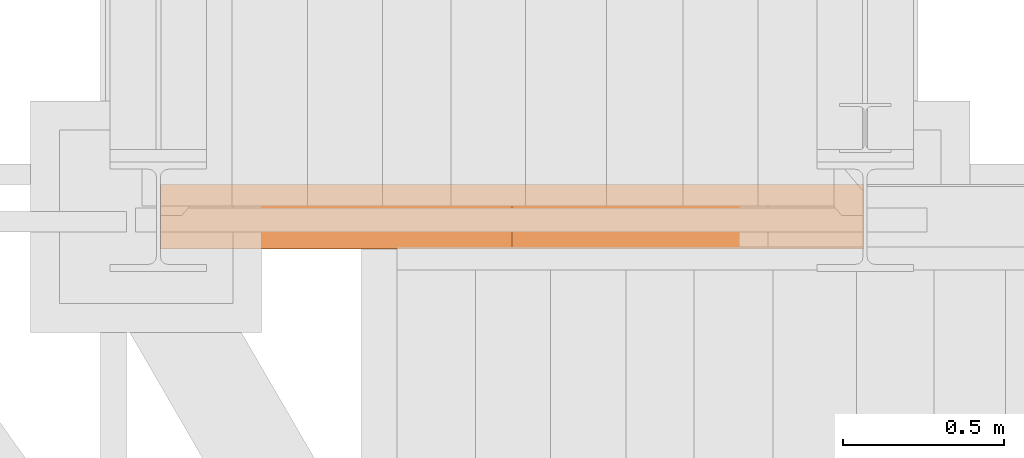
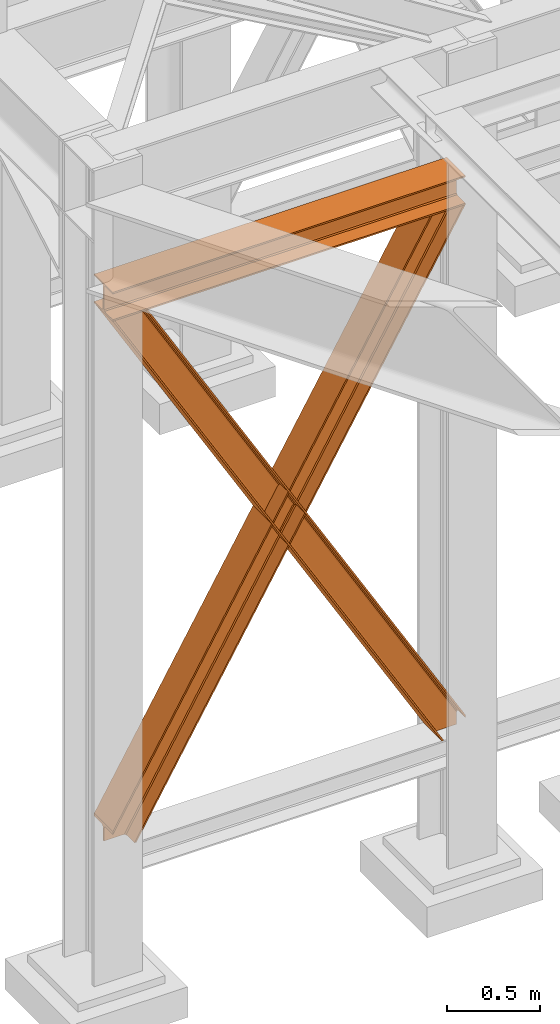
# One storey, part 20 of 208: 3 proxies.
"""IFC2X3 building model written with IfcOpenShell, lengths in millimetres."""

from ifc_helpers import new_model, entity, si_unit, converted_unit, frame, origin, origin_with_axes, place, context, subcontext, project, spatial, faceted_brep, element, save


model = new_model("IFC2X3")

# Units and contexts
model_context = context("Model", 3, precision=1e-05, world=origin())
plan_context = context("Plan", 3, precision=1e-05, world=origin())
body_context = subcontext(model_context, "Body", "Model", "MODEL_VIEW")
ifc_project = project(units=[si_unit("LENGTHUNIT", "METRE", prefix="MILLI"), converted_unit("PLANEANGLEUNIT", "DEGREE", entity("IfcPlaneAngleMeasure", 0.0174532925199433), si_unit("PLANEANGLEUNIT", "RADIAN"), dimensions=[0, 0, 0, 0, 0, 0, 0]), si_unit("AREAUNIT", "SQUARE_METRE"), si_unit("VOLUMEUNIT", "CUBIC_METRE")], contexts=[model_context, plan_context])

# Building, storey
building_placement = place(None, origin())
building = spatial("IfcBuilding", under=ifc_project, at=building_placement, CompositionType="COMPLEX")
storey_placement = place(building_placement, origin_with_axes())
storey = spatial("IfcBuildingStorey", under=building, at=storey_placement, Name="Geschoss", CompositionType="ELEMENT")

# Proxies
proxy_1_placement = place(storey_placement, frame((-3299.995025406559, -17362.5323246858, 4202.989992847441), z_axis=(0.0, 0.0, 1.0), x_axis=(1.0, 0.0, 0.0)))
element("IfcBuildingElementProxy", 1, at=proxy_1_placement, inside=storey, context=body_context, shape_type="Brep", body=[
    faceted_brep([(2188.00999989569, 0.00999999999839929, 190.0100125169756), (2188.00999989569, 200.0100029802306, 190.0100125169756), (2188.00999989569, 200.0100029802306, 180.0100146031382), (2188.00999989569, 121.2600035762771, 180.0100071525576), (2188.00999989569, 111.9441915473326, 178.1454621052744), (2188.00999989569, 105.1245498640819, 171.3258190250399), (2188.00999989569, 103.2600015571697, 162.010007927418), (2188.00999989569, 103.2600015571697, 28.00999713897727), (2188.00999989569, 105.1245498640819, 18.69418604135535), (2188.00999989569, 111.9441915473326, 11.87454296112082), (2188.00999989569, 121.2600035762771, 10.00999791383765), (2188.00999989569, 200.0100029802306, 10.00999791383765), (2188.00999989569, 200.0100029802306, 0.01000000000021828), (2188.00999989569, 0.00999999999839929, 0.01000000000021828), (2188.00999989569, 0.00999999999839929, 10.00999791383765), (2188.00999989569, 78.75999940395195, 10.00999791383765), (2188.00999989569, 88.07581143289644, 11.87454296112082), (2188.00999989569, 94.89545311614711, 18.69418604135535), (2188.00999989569, 96.7600014230593, 28.00999713897727), (2188.00999989569, 96.7600014230593, 162.010007927418), (2188.00999989569, 94.89545311614711, 171.3258190250399), (2188.00999989569, 88.07581143289644, 178.1454621052744), (2188.00999989569, 78.75999940395195, 180.0100071525576), (2188.00999989569, 0.00999999999839929, 180.0100146031382), (2188.00999989569, 200.0100029802306, 190.0100125169756), (2188.00999989569, 0.00999999999839929, 190.0100125169756), (0.01000000000021828, 0.00999999999839929, 190.0100125169756), (0.01000000000021828, 200.0100029802306, 190.0100125169756), (2188.00999989569, 200.0100029802306, 180.0100146031382), (2188.00999989569, 200.0100029802306, 190.0100125169756), (0.01000000000021828, 200.0100029802306, 190.0100125169756), (0.01000000000021828, 200.0100029802306, 180.0100146031382), (2188.00999989569, 121.2600035762771, 180.0100071525576), (2188.00999989569, 200.0100029802306, 180.0100146031382), (0.01000000000021828, 200.0100029802306, 180.0100146031382), (0.01000000000021828, 121.2600035762771, 180.0100071525576), (2188.00999989569, 111.9441915473326, 178.1454621052744), (2188.00999989569, 121.2600035762771, 180.0100071525576), (0.01000000000021828, 121.2600035762771, 180.0100071525576), (0.01000000000021828, 111.9441915473326, 178.1454621052744), (2188.00999989569, 105.1245498640819, 171.3258190250399), (2188.00999989569, 111.9441915473326, 178.1454621052744), (0.01000000000021828, 111.9441915473326, 178.1454621052744), (0.01000000000021828, 105.1245498640819, 171.3258190250399), (2188.00999989569, 103.2600015571697, 162.010007927418), (2188.00999989569, 105.1245498640819, 171.3258190250399), (0.01000000000021828, 105.1245498640819, 171.3258190250399), (0.01000000000021828, 103.2600015571697, 162.010007927418), (2188.00999989569, 103.2600015571697, 28.00999713897727), (2188.00999989569, 103.2600015571697, 162.010007927418), (0.01000000000021828, 103.2600015571697, 162.010007927418), (0.01000000000021828, 103.2600015571697, 28.00999713897727), (2188.00999989569, 105.1245498640819, 18.69418604135535), (2188.00999989569, 103.2600015571697, 28.00999713897727), (0.01000000000021828, 103.2600015571697, 28.00999713897727), (0.01000000000021828, 105.1245498640819, 18.69418604135535), (2188.00999989569, 111.9441915473326, 11.87454296112082), (2188.00999989569, 105.1245498640819, 18.69418604135535), (0.01000000000021828, 105.1245498640819, 18.69418604135535), (0.01000000000021828, 111.9441915473326, 11.87454296112082), (2188.00999989569, 121.2600035762771, 10.00999791383765), (2188.00999989569, 111.9441915473326, 11.87454296112082), (0.01000000000021828, 111.9441915473326, 11.87454296112082), (0.01000000000021828, 121.2600035762771, 10.00999791383765), (2188.00999989569, 200.0100029802306, 10.00999791383765), (2188.00999989569, 121.2600035762771, 10.00999791383765), (0.01000000000021828, 121.2600035762771, 10.00999791383765), (0.01000000000021828, 200.0100029802306, 10.00999791383765), (2188.00999989569, 200.0100029802306, 0.01000000000021828), (2188.00999989569, 200.0100029802306, 10.00999791383765), (0.01000000000021828, 200.0100029802306, 10.00999791383765), (0.01000000000021828, 200.0100029802306, 0.01000000000021828), (2188.00999989569, 0.00999999999839929, 0.01000000000021828), (2188.00999989569, 200.0100029802306, 0.01000000000021828), (0.01000000000021828, 200.0100029802306, 0.01000000000021828), (0.01000000000021828, 0.00999999999839929, 0.01000000000021828), (2188.00999989569, 0.00999999999839929, 10.00999791383765), (2188.00999989569, 0.00999999999839929, 0.01000000000021828), (0.01000000000021828, 0.00999999999839929, 0.01000000000021828), (0.01000000000021828, 0.00999999999839929, 10.00999791383765), (2188.00999989569, 78.75999940395195, 10.00999791383765), (2188.00999989569, 0.00999999999839929, 10.00999791383765), (0.01000000000021828, 0.00999999999839929, 10.00999791383765), (0.01000000000021828, 78.75999940395195, 10.00999791383765), (2188.00999989569, 88.07581143289644, 11.87454296112082), (2188.00999989569, 78.75999940395195, 10.00999791383765), (0.01000000000021828, 78.75999940395195, 10.00999791383765), (0.01000000000021828, 88.07581143289644, 11.87454296112082), (2188.00999989569, 94.89545311614711, 18.69418604135535), (2188.00999989569, 88.07581143289644, 11.87454296112082), (0.01000000000021828, 88.07581143289644, 11.87454296112082), (0.01000000000021828, 94.89545311614711, 18.69418604135535), (2188.00999989569, 96.7600014230593, 28.00999713897727), (2188.00999989569, 94.89545311614711, 18.69418604135535), (0.01000000000021828, 94.89545311614711, 18.69418604135535), (0.01000000000021828, 96.7600014230593, 28.00999713897727), (2188.00999989569, 96.7600014230593, 162.010007927418), (2188.00999989569, 96.7600014230593, 28.00999713897727), (0.01000000000021828, 96.7600014230593, 28.00999713897727), (0.01000000000021828, 96.7600014230593, 162.010007927418), (2188.00999989569, 94.89545311614711, 171.3258190250399), (2188.00999989569, 96.7600014230593, 162.010007927418), (0.01000000000021828, 96.7600014230593, 162.010007927418), (0.01000000000021828, 94.89545311614711, 171.3258190250399), (2188.00999989569, 88.07581143289644, 178.1454621052744), (2188.00999989569, 94.89545311614711, 171.3258190250399), (0.01000000000021828, 94.89545311614711, 171.3258190250399), (0.01000000000021828, 88.07581143289644, 178.1454621052744), (2188.00999989569, 78.75999940395195, 180.0100071525576), (2188.00999989569, 88.07581143289644, 178.1454621052744), (0.01000000000021828, 88.07581143289644, 178.1454621052744), (0.01000000000021828, 78.75999940395195, 180.0100071525576), (2188.00999989569, 0.00999999999839929, 180.0100146031382), (2188.00999989569, 78.75999940395195, 180.0100071525576), (0.01000000000021828, 78.75999940395195, 180.0100071525576), (0.01000000000021828, 0.00999999999839929, 180.0100146031382), (2188.00999989569, 0.00999999999839929, 190.0100125169756), (2188.00999989569, 0.00999999999839929, 180.0100146031382), (0.01000000000021828, 0.00999999999839929, 180.0100146031382), (0.01000000000021828, 0.00999999999839929, 190.0100125169756), (0.01000000000021828, 0.00999999999839929, 190.0100125169756), (0.01000000000021828, 0.00999999999839929, 180.0100146031382), (0.01000000000021828, 78.75999940395195, 180.0100071525576), (0.01000000000021828, 88.07581143289644, 178.1454621052744), (0.01000000000021828, 94.89545311614711, 171.3258190250399), (0.01000000000021828, 96.7600014230593, 162.010007927418), (0.01000000000021828, 96.7600014230593, 28.00999713897727), (0.01000000000021828, 94.89545311614711, 18.69418604135535), (0.01000000000021828, 88.07581143289644, 11.87454296112082), (0.01000000000021828, 78.75999940395195, 10.00999791383765), (0.01000000000021828, 0.00999999999839929, 10.00999791383765), (0.01000000000021828, 0.00999999999839929, 0.01000000000021828), (0.01000000000021828, 200.0100029802306, 0.01000000000021828), (0.01000000000021828, 200.0100029802306, 10.00999791383765), (0.01000000000021828, 121.2600035762771, 10.00999791383765), (0.01000000000021828, 111.9441915473326, 11.87454296112082), (0.01000000000021828, 105.1245498640819, 18.69418604135535), (0.01000000000021828, 103.2600015571697, 28.00999713897727), (0.01000000000021828, 103.2600015571697, 162.010007927418), (0.01000000000021828, 105.1245498640819, 171.3258190250399), (0.01000000000021828, 111.9441915473326, 178.1454621052744), (0.01000000000021828, 121.2600035762771, 180.0100071525576), (0.01000000000021828, 200.0100029802306, 180.0100146031382), (0.01000000000021828, 200.0100029802306, 190.0100125169756)], [[[0, 1, 2, 3, 4, 5, 6, 7, 8, 9, 10, 11, 12, 13, 14, 15, 16, 17, 18, 19, 20, 21, 22, 23]], [[24, 25, 26, 27]], [[28, 29, 30, 31]], [[32, 33, 34, 35]], [[36, 37, 38, 39]], [[40, 41, 42, 43]], [[44, 45, 46, 47]], [[48, 49, 50, 51]], [[52, 53, 54, 55]], [[56, 57, 58, 59]], [[60, 61, 62, 63]], [[64, 65, 66, 67]], [[68, 69, 70, 71]], [[72, 73, 74, 75]], [[76, 77, 78, 79]], [[80, 81, 82, 83]], [[84, 85, 86, 87]], [[88, 89, 90, 91]], [[92, 93, 94, 95]], [[96, 97, 98, 99]], [[100, 101, 102, 103]], [[104, 105, 106, 107]], [[108, 109, 110, 111]], [[112, 113, 114, 115]], [[116, 117, 118, 119]], [[120, 121, 122, 123, 124, 125, 126, 127, 128, 129, 130, 131, 132, 133, 134, 135, 136, 137, 138, 139, 140, 141, 142, 143]]], orient=[[False], [False], [False], [False], [False], [False], [False], [False], [False], [False], [False], [False], [False], [False], [False], [False], [False], [False], [False], [False], [False], [False], [False], [False], [False], [False]]),
])
proxy_2_placement = place(storey_placement, frame((-3299.41754344748, -17362.5323246858, 734.9900149335328), z_axis=(0.0, 0.0, 1.0), x_axis=(1.0, 0.0, 0.0)))
element("IfcBuildingElementProxy", 2, at=proxy_2_placement, inside=storey, context=body_context, shape_type="Brep", body=[
    faceted_brep([(2187.432517936612, 0.00999999999839929, 120.8497915510925), (216.8471928951321, 0.00999999999839929, 3468.009977913908), (216.8471928951321, 200.0100029802306, 3468.009977913908), (2187.432517936612, 200.0100029802306, 120.8497915510925), (2187.432517936612, 200.0100029802306, 120.8497915510925), (216.8471928951321, 200.0100029802306, 3468.009977913908), (205.4347121912169, 200.0100029802306, 3468.009977913908), (2187.432517936612, 200.0100029802306, 101.4682129393399), (2187.432517936612, 200.0100029802306, 101.4682129393399), (205.4347121912169, 200.0100029802306, 3468.009977913908), (205.4347036882541, 121.2600035762771, 3468.009977913908), (2187.432517936951, 121.2600035762771, 101.4681984983712), (2187.432517936951, 121.2600035762771, 101.4681984983712), (205.4347036882541, 121.2600035762771, 3468.009977913908), (203.306794806967, 111.9441915473326, 3468.009977913909), (2187.432602958225, 111.9441915473326, 97.8542740943027), (2187.432602958225, 111.9441915473326, 97.8542740943027), (203.306794806967, 111.9441915473326, 3468.009977913909), (195.5238886772499, 105.1245498640819, 3468.009977913908), (2187.432517936612, 105.1245498640819, 84.63689245399053), (2187.432517936612, 105.1245498640819, 84.63689245399053), (195.5238886772499, 105.1245498640819, 3468.009977913908), (184.892235020021, 103.2600015571697, 3468.009977913908), (2187.432517936612, 103.2600015571697, 66.58142866151934), (2187.432517936612, 103.2600015571697, 0.01000000000010459), (2187.432517936612, 103.2600015571697, 66.58142866151934), (184.892235020021, 103.2600015571697, 3468.009977913908), (31.96494937214857, 103.2600015571697, 3468.009977913908), (2073.723887154785, 103.2600015571697, 0.01000000000033197), (2073.723887154785, 103.2600015571697, 0.01000000000033197), (31.96494937214857, 103.2600015571697, 3468.009977913908), (21.33329571491913, 105.1245498640819, 3468.009977913908), (2063.093996904378, 105.1245498640819, 0.01000000000021828), (2063.093996904378, 105.1245498640819, 0.01000000000021828), (21.33329571491913, 105.1245498640819, 3468.009977913908), (13.55038958520254, 111.9441915473326, 3468.009977913908), (2055.312379673187, 111.9441915473326, 0.009999999999877218), (2055.312379673187, 111.9441915473326, 0.009999999999877218), (13.55038958520254, 111.9441915473326, 3468.009977913908), (11.42248070391588, 121.2600035762771, 3468.009977913907), (2053.184822892689, 121.2600035762771, 0.009999999999877218), (2053.184822892689, 121.2600035762771, 0.009999999999877218), (11.42248070391588, 121.2600035762771, 3468.009977913907), (11.42248070391634, 200.0100029802306, 3468.009977913907), (2053.184822892689, 200.0100029802306, 0.009999999999877218), (2053.184822892689, 200.0100029802306, 0.009999999999877218), (11.42248070391634, 200.0100029802306, 3468.009977913907), (0.01000000000021828, 200.0100029802306, 3468.009977913908), (2041.774228435659, 200.0100029802306, 0.01000000000010459), (2041.774228435659, 200.0100029802306, 0.01000000000010459), (0.01000000000021828, 200.0100029802306, 3468.009977913908), (0.01000000000021828, 0.00999999999839929, 3468.009977913908), (2041.774228435659, 0.00999999999839929, 0.01000000000010459), (2041.774228435659, 0.00999999999839929, 0.01000000000010459), (0.01000000000021828, 0.00999999999839929, 3468.009977913908), (11.42248070391679, 0.00999999999839929, 3468.009977913908), (2053.184822892689, 0.00999999999839929, 0.009999999999990905), (2053.184822892689, 0.00999999999839929, 0.009999999999990905), (11.42248070391679, 0.00999999999839929, 3468.009977913908), (11.42248070391634, 78.75999940395195, 3468.009977913907), (2053.184822892689, 78.75999940395195, 0.009999999999877218), (2053.184822892689, 78.75999940395195, 0.009999999999877218), (11.42248070391634, 78.75999940395195, 3468.009977913907), (13.55038958520254, 88.07581143290008, 3468.009977913908), (2055.312379673187, 88.07581143289644, 0.009999999999877218), (2055.312379673187, 88.07581143289644, 0.009999999999877218), (13.55038958520254, 88.07581143290008, 3468.009977913908), (21.33329571491913, 94.89545311614711, 3468.009977913908), (2063.093996904379, 94.89545311614711, 0.009999999999877218), (2063.093996904379, 94.89545311614711, 0.009999999999877218), (21.33329571491913, 94.89545311614711, 3468.009977913908), (31.96494937214857, 96.7600014230593, 3468.009977913908), (2073.723887154785, 96.7600014230593, 0.01000000000033197), (2073.723887154785, 96.7600014230593, 0.01000000000033197), (31.96494937214857, 96.7600014230593, 3468.009977913908), (184.892235020021, 96.7600014230593, 3468.009977913908), (2187.432517936612, 96.7600014230593, 66.581428661519), (2187.432517936612, 96.7600014230593, 0.01000000000010459), (2187.432517936612, 96.7600014230593, 66.581428661519), (184.892235020021, 96.7600014230593, 3468.009977913908), (195.5238886772499, 94.89545311614711, 3468.009977913908), (2187.432517936612, 94.89545311615075, 84.63689245399053), (2187.432517936612, 94.89545311615075, 84.63689245399053), (195.5238886772499, 94.89545311614711, 3468.009977913908), (203.306794806967, 88.07581143289644, 3468.009977913909), (2187.432517936612, 88.07581143289644, 97.85441850857103), (2187.432517936612, 88.07581143289644, 97.85441850857103), (203.306794806967, 88.07581143289644, 3468.009977913909), (205.4347036882546, 78.75999940395195, 3468.009977913908), (2187.432433072335, 78.75999940395195, 101.4683426459952), (2187.432433072335, 78.75999940395195, 101.4683426459952), (205.4347036882546, 78.75999940395195, 3468.009977913908), (205.4347121912169, 0.00999999999839929, 3468.009977913908), (2187.432517936272, 0.00999999999839929, 101.4682129399165), (2187.432517936272, 0.00999999999839929, 101.4682129399165), (205.4347121912169, 0.00999999999839929, 3468.009977913908), (216.8471928951321, 0.00999999999839929, 3468.009977913908), (2187.432517936612, 0.00999999999839929, 120.8497915510925), (216.8471928951321, 0.00999999999839929, 3468.009977913908), (205.4347121912169, 0.00999999999839929, 3468.009977913908), (205.4347036882546, 78.75999940395195, 3468.009977913908), (203.306794806967, 88.07581143289644, 3468.009977913909), (195.5238886772499, 94.89545311614711, 3468.009977913908), (184.892235020021, 96.7600014230593, 3468.009977913908), (31.96494937214857, 96.7600014230593, 3468.009977913908), (21.33329571491913, 94.89545311614711, 3468.009977913908), (13.55038958520254, 88.07581143290008, 3468.009977913908), (11.42248070391634, 78.75999940395195, 3468.009977913907), (11.42248070391679, 0.00999999999839929, 3468.009977913908), (0.01000000000021828, 0.00999999999839929, 3468.009977913908), (0.01000000000021828, 200.0100029802306, 3468.009977913908), (11.42248070391634, 200.0100029802306, 3468.009977913907), (11.42248070391588, 121.2600035762771, 3468.009977913907), (13.55038958520254, 111.9441915473326, 3468.009977913908), (21.33329571491913, 105.1245498640819, 3468.009977913908), (31.96494937214857, 103.2600015571697, 3468.009977913908), (184.892235020021, 103.2600015571697, 3468.009977913908), (195.5238886772499, 105.1245498640819, 3468.009977913908), (203.306794806967, 111.9441915473326, 3468.009977913909), (205.4347036882541, 121.2600035762771, 3468.009977913908), (205.4347121912169, 200.0100029802306, 3468.009977913908), (216.8471928951321, 200.0100029802306, 3468.009977913908), (2187.432517936612, 96.7600014230593, 0.01000000000010459), (2187.432517936612, 96.7600014230593, 66.581428661519), (2187.432517936612, 94.89545311615075, 84.63689245399053), (2187.432517936612, 88.07581143289644, 97.85441850857103), (2187.432433072335, 78.75999940395195, 101.4683426459952), (2187.432517936272, 0.00999999999839929, 101.4682129399165), (2187.432517936612, 0.00999999999839929, 120.8497915510925), (2187.432517936612, 200.0100029802306, 120.8497915510925), (2187.432517936612, 200.0100029802306, 101.4682129393399), (2187.432517936951, 121.2600035762771, 101.4681984983712), (2187.432602958225, 111.9441915473326, 97.8542740943027), (2187.432517936612, 105.1245498640819, 84.63689245399053), (2187.432517936612, 103.2600015571697, 66.58142866151934), (2187.432517936612, 103.2600015571697, 0.01000000000010459), (2073.723887154785, 103.2600015571697, 0.01000000000033197), (2063.093996904378, 105.1245498640819, 0.01000000000021828), (2055.312379673187, 111.9441915473326, 0.009999999999877218), (2053.184822892689, 121.2600035762771, 0.009999999999877218), (2053.184822892689, 200.0100029802306, 0.009999999999877218), (2041.774228435659, 200.0100029802306, 0.01000000000010459), (2041.774228435659, 0.00999999999839929, 0.01000000000010459), (2053.184822892689, 0.00999999999839929, 0.009999999999990905), (2053.184822892689, 78.75999940395195, 0.009999999999877218), (2055.312379673187, 88.07581143289644, 0.009999999999877218), (2063.093996904379, 94.89545311614711, 0.009999999999877218), (2073.723887154785, 96.7600014230593, 0.01000000000033197), (2187.432517936612, 96.7600014230593, 0.01000000000010459), (2187.432517936612, 103.2600015571697, 0.01000000000010459)], [[[0, 1, 2, 3]], [[4, 5, 6, 7]], [[8, 9, 10, 11]], [[12, 13, 14, 15]], [[16, 17, 18, 19]], [[20, 21, 22, 23]], [[24, 25, 26, 27, 28]], [[29, 30, 31, 32]], [[33, 34, 35, 36]], [[37, 38, 39, 40]], [[41, 42, 43, 44]], [[45, 46, 47, 48]], [[49, 50, 51, 52]], [[53, 54, 55, 56]], [[57, 58, 59, 60]], [[61, 62, 63, 64]], [[65, 66, 67, 68]], [[69, 70, 71, 72]], [[73, 74, 75, 76, 77]], [[78, 79, 80, 81]], [[82, 83, 84, 85]], [[86, 87, 88, 89]], [[90, 91, 92, 93]], [[94, 95, 96, 97]], [[98, 99, 100, 101, 102, 103, 104, 105, 106, 107, 108, 109, 110, 111, 112, 113, 114, 115, 116, 117, 118, 119, 120, 121]], [[122, 123, 124, 125, 126, 127, 128, 129, 130, 131, 132, 133, 134, 135]], [[136, 137, 138, 139, 140, 141, 142, 143, 144, 145, 146, 147, 148, 149]]], orient=[[False], [False], [False], [False], [False], [False], [False], [False], [False], [False], [False], [False], [False], [False], [False], [False], [False], [False], [False], [False], [False], [False], [False], [False], [False], [False], [False]]),
])
proxy_3_placement = place(storey_placement, frame((-3299.995110428173, -17362.5323246858, 734.9900149335328), z_axis=(0.0, 0.0, 1.0), x_axis=(1.0, 0.0, 0.0)))
element("IfcBuildingElementProxy", 3, at=proxy_3_placement, inside=storey, context=body_context, shape_type="Brep", body=[
    faceted_brep([(0.01008502161403158, 0.00999999999839929, 120.8497915510925), (0.01008502161403158, 200.0100029802306, 120.8497915510925), (1970.595410063094, 200.0100029802306, 3468.009977913908), (1970.595410063094, 0.00999999999839929, 3468.009977913908), (0.01008502161403158, 200.0100029802306, 120.8497915510925), (0.01008502161357683, 200.0100029802306, 101.4682129393399), (1982.007890767009, 200.0100029802306, 3468.009977913908), (1970.595410063094, 200.0100029802306, 3468.009977913908), (0.01008502161357683, 200.0100029802306, 101.4682129393399), (0.01008502127479005, 121.2600035762771, 101.4681984983712), (1982.007899269972, 121.2600035762771, 3468.009977913908), (1982.007890767009, 200.0100029802306, 3468.009977913908), (0.01008502127479005, 121.2600035762771, 101.4681984983712), (0.01000000000021828, 111.9441915473326, 97.8542740943027), (1984.135808151259, 111.9441915473326, 3468.009977913909), (1982.007899269972, 121.2600035762771, 3468.009977913908), (0.01000000000021828, 111.9441915473326, 97.8542740943027), (0.01008502161403158, 105.1245498640819, 84.63689245399053), (1991.918714280976, 105.1245498640819, 3468.009977913908), (1984.135808151259, 111.9441915473326, 3468.009977913909), (0.01008502161403158, 105.1245498640819, 84.63689245399053), (0.01008502161403158, 103.2600015571697, 66.58142866151934), (2002.550367938205, 103.2600015571697, 3468.009977913908), (1991.918714280976, 105.1245498640819, 3468.009977913908), (0.01008502161403158, 103.2600015571697, 0.01000000000010459), (113.7187158034403, 103.2600015571697, 0.01000000000033197), (2155.477653586077, 103.2600015571697, 3468.009977913908), (2002.550367938205, 103.2600015571697, 3468.009977913908), (0.01008502161403158, 103.2600015571697, 66.58142866151934), (113.7187158034403, 103.2600015571697, 0.01000000000033197), (124.3486060538471, 105.1245498640819, 0.01000000000021828), (2166.109307243307, 105.1245498640819, 3468.009977913908), (2155.477653586077, 103.2600015571697, 3468.009977913908), (124.3486060538471, 105.1245498640819, 0.01000000000021828), (132.1302232850385, 111.9441915473326, 0.009999999999877218), (2173.892213373023, 111.9441915473326, 3468.009977913908), (2166.109307243307, 105.1245498640819, 3468.009977913908), (132.1302232850385, 111.9441915473326, 0.009999999999877218), (134.2577800655372, 121.2600035762771, 0.009999999999877218), (2176.02012225431, 121.2600035762771, 3468.009977913907), (2173.892213373023, 111.9441915473326, 3468.009977913908), (134.2577800655372, 121.2600035762771, 0.009999999999877218), (134.2577800655372, 200.0100029802306, 0.009999999999877218), (2176.020122254309, 200.0100029802306, 3468.009977913907), (2176.02012225431, 121.2600035762771, 3468.009977913907), (134.2577800655372, 200.0100029802306, 0.009999999999877218), (145.6683745225669, 200.0100029802306, 0.01000000000010459), (2187.432602958225, 200.0100029802306, 3468.009977913908), (2176.020122254309, 200.0100029802306, 3468.009977913907), (145.6683745225669, 200.0100029802306, 0.01000000000010459), (145.6683745225669, 0.00999999999839929, 0.01000000000010459), (2187.432602958225, 0.00999999999839929, 3468.009977913908), (2187.432602958225, 200.0100029802306, 3468.009977913908), (145.6683745225669, 0.00999999999839929, 0.01000000000010459), (134.2577800655372, 0.00999999999839929, 0.009999999999990905), (2176.020122254309, 0.00999999999839929, 3468.009977913908), (2187.432602958225, 0.00999999999839929, 3468.009977913908), (134.2577800655372, 0.00999999999839929, 0.009999999999990905), (134.2577800655372, 78.75999940395195, 0.009999999999877218), (2176.020122254309, 78.75999940395195, 3468.009977913907), (2176.020122254309, 0.00999999999839929, 3468.009977913908), (134.2577800655372, 78.75999940395195, 0.009999999999877218), (132.1302232850385, 88.07581143289644, 0.009999999999877218), (2173.892213373023, 88.07581143290008, 3468.009977913908), (2176.020122254309, 78.75999940395195, 3468.009977913907), (132.1302232850385, 88.07581143289644, 0.009999999999877218), (124.3486060538467, 94.89545311614711, 0.009999999999877218), (2166.109307243307, 94.89545311614711, 3468.009977913908), (2173.892213373023, 88.07581143290008, 3468.009977913908), (124.3486060538467, 94.89545311614711, 0.009999999999877218), (113.7187158034403, 96.7600014230593, 0.01000000000033197), (2155.477653586077, 96.7600014230593, 3468.009977913908), (2166.109307243307, 94.89545311614711, 3468.009977913908), (113.7187158034403, 96.7600014230593, 0.01000000000033197), (0.01008502161357683, 96.7600014230593, 0.01000000000010459), (0.01008502161403158, 96.7600014230593, 66.581428661519), (2002.550367938205, 96.7600014230593, 3468.009977913908), (2155.477653586077, 96.7600014230593, 3468.009977913908), (0.01008502161403158, 96.7600014230593, 66.581428661519), (0.01008502161403158, 94.89545311615075, 84.63689245399053), (1991.918714280976, 94.89545311614711, 3468.009977913908), (2002.550367938205, 96.7600014230593, 3468.009977913908), (0.01008502161403158, 94.89545311615075, 84.63689245399053), (0.01008502161403158, 88.07581143289644, 97.85441850857103), (1984.135808151259, 88.07581143289644, 3468.009977913909), (1991.918714280976, 94.89545311614711, 3468.009977913908), (0.01008502161403158, 88.07581143289644, 97.85441850857103), (0.01016988589071843, 78.75999940395195, 101.4683426459952), (1982.007899269972, 78.75999940395195, 3468.009977913908), (1984.135808151259, 88.07581143289644, 3468.009977913909), (0.01016988589071843, 78.75999940395195, 101.4683426459952), (0.0100850219532731, 0.00999999999839929, 101.4682129399165), (1982.007890767009, 0.00999999999839929, 3468.009977913908), (1982.007899269972, 78.75999940395195, 3468.009977913908), (0.0100850219532731, 0.00999999999839929, 101.4682129399165), (0.01008502161403158, 0.00999999999839929, 120.8497915510925), (1970.595410063094, 0.00999999999839929, 3468.009977913908), (1982.007890767009, 0.00999999999839929, 3468.009977913908), (1970.595410063094, 0.00999999999839929, 3468.009977913908), (1970.595410063094, 200.0100029802306, 3468.009977913908), (1982.007890767009, 200.0100029802306, 3468.009977913908), (1982.007899269972, 121.2600035762771, 3468.009977913908), (1984.135808151259, 111.9441915473326, 3468.009977913909), (1991.918714280976, 105.1245498640819, 3468.009977913908), (2002.550367938205, 103.2600015571697, 3468.009977913908), (2155.477653586077, 103.2600015571697, 3468.009977913908), (2166.109307243307, 105.1245498640819, 3468.009977913908), (2173.892213373023, 111.9441915473326, 3468.009977913908), (2176.02012225431, 121.2600035762771, 3468.009977913907), (2176.020122254309, 200.0100029802306, 3468.009977913907), (2187.432602958225, 200.0100029802306, 3468.009977913908), (2187.432602958225, 0.00999999999839929, 3468.009977913908), (2176.020122254309, 0.00999999999839929, 3468.009977913908), (2176.020122254309, 78.75999940395195, 3468.009977913907), (2173.892213373023, 88.07581143290008, 3468.009977913908), (2166.109307243307, 94.89545311614711, 3468.009977913908), (2155.477653586077, 96.7600014230593, 3468.009977913908), (2002.550367938205, 96.7600014230593, 3468.009977913908), (1991.918714280976, 94.89545311614711, 3468.009977913908), (1984.135808151259, 88.07581143289644, 3468.009977913909), (1982.007899269972, 78.75999940395195, 3468.009977913908), (1982.007890767009, 0.00999999999839929, 3468.009977913908), (0.01008502161357683, 96.7600014230593, 0.01000000000010459), (0.01008502161403158, 103.2600015571697, 0.01000000000010459), (0.01008502161403158, 103.2600015571697, 66.58142866151934), (0.01008502161403158, 105.1245498640819, 84.63689245399053), (0.01000000000021828, 111.9441915473326, 97.8542740943027), (0.01008502127479005, 121.2600035762771, 101.4681984983712), (0.01008502161357683, 200.0100029802306, 101.4682129393399), (0.01008502161403158, 200.0100029802306, 120.8497915510925), (0.01008502161403158, 0.00999999999839929, 120.8497915510925), (0.0100850219532731, 0.00999999999839929, 101.4682129399165), (0.01016988589071843, 78.75999940395195, 101.4683426459952), (0.01008502161403158, 88.07581143289644, 97.85441850857103), (0.01008502161403158, 94.89545311615075, 84.63689245399053), (0.01008502161403158, 96.7600014230593, 66.581428661519), (113.7187158034403, 103.2600015571697, 0.01000000000033197), (0.01008502161403158, 103.2600015571697, 0.01000000000010459), (0.01008502161357683, 96.7600014230593, 0.01000000000010459), (113.7187158034403, 96.7600014230593, 0.01000000000033197), (124.3486060538467, 94.89545311614711, 0.009999999999877218), (132.1302232850385, 88.07581143289644, 0.009999999999877218), (134.2577800655372, 78.75999940395195, 0.009999999999877218), (134.2577800655372, 0.00999999999839929, 0.009999999999990905), (145.6683745225669, 0.00999999999839929, 0.01000000000010459), (145.6683745225669, 200.0100029802306, 0.01000000000010459), (134.2577800655372, 200.0100029802306, 0.009999999999877218), (134.2577800655372, 121.2600035762771, 0.009999999999877218), (132.1302232850385, 111.9441915473326, 0.009999999999877218), (124.3486060538471, 105.1245498640819, 0.01000000000021828)], [[[0, 1, 2, 3]], [[4, 5, 6, 7]], [[8, 9, 10, 11]], [[12, 13, 14, 15]], [[16, 17, 18, 19]], [[20, 21, 22, 23]], [[24, 25, 26, 27, 28]], [[29, 30, 31, 32]], [[33, 34, 35, 36]], [[37, 38, 39, 40]], [[41, 42, 43, 44]], [[45, 46, 47, 48]], [[49, 50, 51, 52]], [[53, 54, 55, 56]], [[57, 58, 59, 60]], [[61, 62, 63, 64]], [[65, 66, 67, 68]], [[69, 70, 71, 72]], [[73, 74, 75, 76, 77]], [[78, 79, 80, 81]], [[82, 83, 84, 85]], [[86, 87, 88, 89]], [[90, 91, 92, 93]], [[94, 95, 96, 97]], [[98, 99, 100, 101, 102, 103, 104, 105, 106, 107, 108, 109, 110, 111, 112, 113, 114, 115, 116, 117, 118, 119, 120, 121]], [[122, 123, 124, 125, 126, 127, 128, 129, 130, 131, 132, 133, 134, 135]], [[136, 137, 138, 139, 140, 141, 142, 143, 144, 145, 146, 147, 148, 149]]], orient=[[False], [False], [False], [False], [False], [False], [False], [False], [False], [False], [False], [False], [False], [False], [False], [False], [False], [False], [False], [False], [False], [False], [False], [False], [False], [False], [False]]),
])

save(model, "model.ifc")
